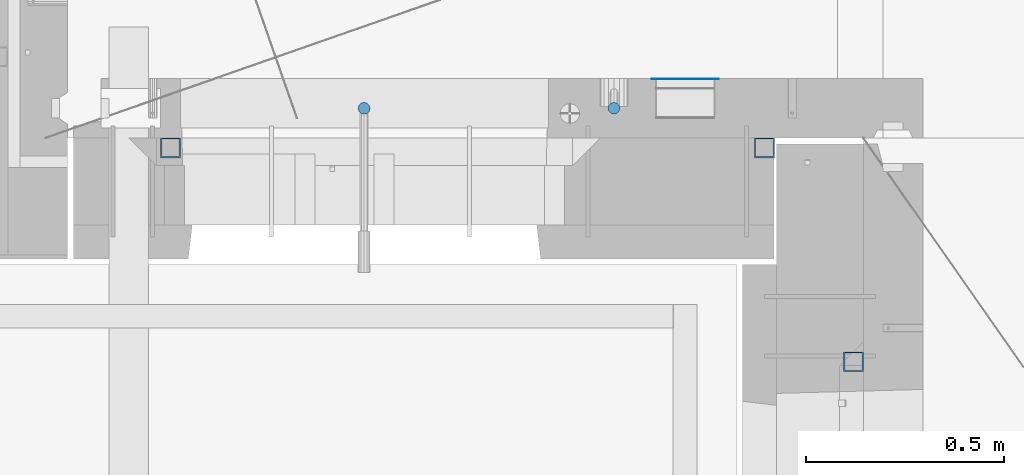
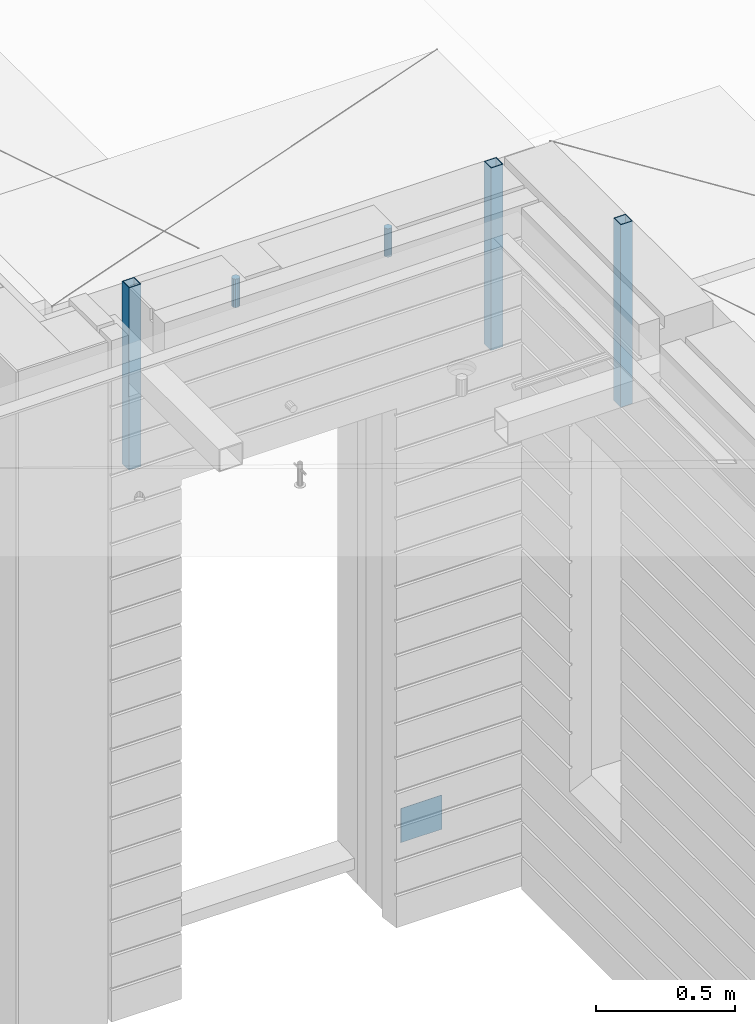
# One storey, part 12 of 350: 6 columns, 6 elements without a shape of their own.
"""IFC2X3 building model written with IfcOpenShell, lengths in millimetres."""

from ifc_helpers import new_model, si_unit, frame, origin_with_axes, place, context, subcontext, project, spatial, faceted_brep, material, type_object, element, aggregate, save


model = new_model("IFC2X3")

# Units and contexts
model_context = context("Model", 3, precision=1e-05, world=origin_with_axes())
body_context = subcontext(model_context, "Body", "Model", "MODEL_VIEW")
ifc_project = project(units=[si_unit("LENGTHUNIT", "METRE", prefix="MILLI"), si_unit("AREAUNIT", "SQUARE_METRE"), si_unit("VOLUMEUNIT", "CUBIC_METRE"), si_unit("MASSUNIT", "GRAM", prefix="KILO"), si_unit("TIMEUNIT", "SECOND"), si_unit("PLANEANGLEUNIT", "RADIAN"), si_unit("SOLIDANGLEUNIT", "STERADIAN"), si_unit("THERMODYNAMICTEMPERATUREUNIT", "DEGREE_CELSIUS"), si_unit("LUMINOUSINTENSITYUNIT", "LUMEN")], contexts=[model_context])

# Site, building, storey
site_placement = place(None, origin_with_axes())
site = spatial("IfcSite", under=ifc_project, at=site_placement, CompositionType="ELEMENT")
building_placement = place(site_placement, origin_with_axes())
building = spatial("IfcBuilding", under=site, at=building_placement, CompositionType="ELEMENT")
storey_placement = place(building_placement, origin_with_axes())
storey = spatial("IfcBuildingStorey", under=building, at=storey_placement, Name="2", CompositionType="ELEMENT", Elevation=0.0)

# Assemblies, columns
assembly_1_placement = place(storey_placement, origin_with_axes())
assembly_1 = element("IfcElementAssembly", 1, at=assembly_1_placement, inside=storey, AssemblyPlace="NOTDEFINED", PredefinedType="REINFORCEMENT_UNIT")
ifc_material_1 = material()
column_type_1 = type_object("IfcColumnType", Name="D30", PredefinedType="NOTDEFINED")
column_1_placement = place(assembly_1_placement, frame((9379.99827996565, 11025.0, 87407.5), z_axis=(0.0, -1.0, 0.0), x_axis=(0.0, 0.0, 1.0)))
column_1 = element("IfcColumn", 2, at=column_1_placement, type_object=column_type_1, material=ifc_material_1, ObjectType="D30", context=body_context, shape_type="Brep", body=[
    faceted_brep([(0.0, -15.0, 0.0), (0.0, -12.9903810567666, -7.5), (125.0, -12.9903810567666, -7.5), (125.0, -15.0, 0.0), (0.0, -7.5, -12.9903810567666), (125.0, -7.5, -12.9903810567666), (0.0, 0.0, -15.0), (125.0, 0.0, -15.0), (0.0, 7.5, -12.9903810567666), (125.0, 7.5, -12.9903810567666), (0.0, 12.9903810567666, -7.5), (125.0, 12.9903810567666, -7.5), (0.0, 15.0, 0.0), (125.0, 15.0, 0.0), (0.0, 12.9903810567666, 7.5), (125.0, 12.9903810567666, 7.5), (0.0, 7.5, 12.9903810567666), (125.0, 7.5, 12.9903810567666), (0.0, 0.0, 15.0), (125.0, 0.0, 15.0), (0.0, -7.5, 12.9903810567666), (125.0, -7.5, 12.9903810567666), (0.0, -12.9903810567666, 7.5), (125.0, -12.9903810567666, 7.5)], [[[0, 1, 2, 3]], [[1, 4, 5, 2]], [[4, 6, 7, 5]], [[6, 8, 9, 7]], [[8, 10, 11, 9]], [[10, 12, 13, 11]], [[12, 14, 15, 13]], [[14, 16, 17, 15]], [[16, 18, 19, 17]], [[18, 20, 21, 19]], [[20, 22, 23, 21]], [[22, 0, 3, 23]], [[5, 7, 9, 11, 13, 15, 17, 19, 21, 23, 3, 2]], [[22, 20, 18, 16, 14, 12, 10, 8, 6, 4, 1, 0]]]),
])
column_2_placement = place(assembly_1_placement, frame((8748.99633326467, 11025.0000000071, 87407.5), z_axis=(0.0, 1.0, 0.0), x_axis=(0.0, 0.0, 1.0)))
column_2 = element("IfcColumn", 3, at=column_2_placement, type_object=column_type_1, material=ifc_material_1, ObjectType="D30", context=body_context, shape_type="Brep", body=[
    faceted_brep([(0.0, -15.0, 0.0), (0.0, -12.9903810567666, -7.5), (125.0, -12.9903810567666, -7.5), (125.0, -15.0, 0.0), (0.0, -7.5, -12.9903810567666), (125.0, -7.5, -12.9903810567666), (0.0, 0.0, -15.0), (125.0, 0.0, -15.0), (0.0, 7.5, -12.9903810567666), (125.0, 7.5, -12.9903810567666), (0.0, 12.9903810567666, -7.5), (125.0, 12.9903810567666, -7.5), (0.0, 15.0, 0.0), (125.0, 15.0, 0.0), (0.0, 12.9903810567666, 7.5), (125.0, 12.9903810567666, 7.5), (0.0, 7.5, 12.9903810567666), (125.0, 7.5, 12.9903810567666), (0.0, 0.0, 15.0), (125.0, 0.0, 15.0), (0.0, -7.5, 12.9903810567666), (125.0, -7.5, 12.9903810567666), (0.0, -12.9903810567666, 7.5), (125.0, -12.9903810567666, 7.5)], [[[0, 1, 2, 3]], [[1, 4, 5, 2]], [[4, 6, 7, 5]], [[6, 8, 9, 7]], [[8, 10, 11, 9]], [[10, 12, 13, 11]], [[12, 14, 15, 13]], [[14, 16, 17, 15]], [[16, 18, 19, 17]], [[18, 20, 21, 19]], [[20, 22, 23, 21]], [[22, 0, 3, 23]], [[5, 7, 9, 11, 13, 15, 17, 19, 21, 23, 3, 2]], [[22, 20, 18, 16, 14, 12, 10, 8, 6, 4, 1, 0]]]),
])
assembly_2_placement = place(assembly_1_placement, origin_with_axes())
assembly_2 = element("IfcElementAssembly", 4, at=assembly_2_placement, Name="Steel Assembly", AssemblyPlace="NOTDEFINED", PredefinedType="NOTDEFINED")
ifc_material_2 = material(Name="Undefined")
column_type_2 = type_object("IfcColumnType", PredefinedType="NOTDEFINED")
column_3_placement = place(assembly_2_placement, frame((9560.0000000031, 11098.9999999984, 84754.9999999985), z_axis=(0.0, 1.0, 0.0), x_axis=(0.0, 0.0, 1.0)))
column_3 = element("IfcColumn", 5, at=column_3_placement, type_object=column_type_2, material=ifc_material_2, Name="SPK2", context=body_context, shape_type="Brep", body=[
    faceted_brep([(0.0, 85.0, -1.0), (0.0, 85.0, 1.0), (150.0, 85.0, 1.0), (150.0, 85.0, -1.0), (0.0, -85.0, 1.0), (150.0, -85.0, 1.0), (0.0, -85.0, -1.0), (150.0, -85.0, -1.0)], [[[0, 1, 2, 3]], [[1, 4, 5, 2]], [[4, 6, 7, 5]], [[6, 0, 3, 7]], [[5, 7, 3, 2]], [[6, 4, 1, 0]]]),
])
aggregate(assembly_2, [column_3])
assembly_3_placement = place(assembly_1_placement, origin_with_axes())
assembly_3 = element("IfcElementAssembly", 6, at=assembly_3_placement, Name="Steel Assembly", AssemblyPlace="NOTDEFINED", PredefinedType="RIGID_FRAME")
ifc_material_3 = material(Name="STEEL/S355J2")
column_type_3 = type_object("IfcColumnType", Name="50X50X3", PredefinedType="NOTDEFINED")
column_4_placement = place(assembly_3_placement, frame((8260.0, 10925.0, 86940.0), z_axis=(1.0, 0.0, 0.0), x_axis=(0.0, 0.0, 1.0)))
column_4 = element("IfcColumn", 7, at=column_4_placement, type_object=column_type_3, material=ifc_material_3, ObjectType="50X50X3", context=body_context, shape_type="Brep", body=[
    faceted_brep([(0.0, 22.0, -22.0), (0.0, -22.0, -22.0), (800.0, -22.0, -22.0), (800.0, 22.0, -22.0), (0.0, -22.0, 22.0), (800.0, -22.0, 22.0), (0.0, 22.0, 22.0), (800.0, 22.0, 22.0), (0.0, 25.0, -25.0), (0.0, 25.0, 25.0), (800.0, 25.0, 25.0), (800.0, 25.0, -25.0), (0.0, -25.0, 25.0), (800.0, -25.0, 25.0), (0.0, -25.0, -25.0), (800.0, -25.0, -25.0)], [[[0, 1, 2, 3]], [[1, 4, 5, 2]], [[4, 6, 7, 5]], [[6, 0, 3, 7]], [[8, 9, 10, 11]], [[9, 12, 13, 10]], [[12, 14, 15, 13]], [[14, 8, 11, 15]], [[13, 15, 11, 10], [5, 7, 3, 2]], [[14, 12, 9, 8], [6, 4, 1, 0]]]),
])
aggregate(assembly_3, [column_4])
assembly_4_placement = place(assembly_1_placement, origin_with_axes())
assembly_4 = element("IfcElementAssembly", 8, at=assembly_4_placement, Name="Steel Assembly", AssemblyPlace="NOTDEFINED", PredefinedType="RIGID_FRAME")
aggregate(assembly_1, [column_1, column_2, assembly_2, assembly_3, assembly_4])
column_5_placement = place(assembly_4_placement, frame((9760.0, 10925.0, 86940.0), z_axis=(1.0, 0.0, 0.0), x_axis=(0.0, 0.0, 1.0)))
column_5 = element("IfcColumn", 9, at=column_5_placement, type_object=column_type_3, material=ifc_material_3, ObjectType="50X50X3", context=body_context, shape_type="Brep", body=[
    faceted_brep([(0.0, 22.0, -22.0), (0.0, -22.0, -22.0), (800.0, -22.0, -22.0), (800.0, 22.0, -22.0), (0.0, -22.0, 22.0), (800.0, -22.0, 22.0), (0.0, 22.0, 22.0), (800.0, 22.0, 22.0), (0.0, 25.0, -25.0), (0.0, 25.0, 25.0), (800.0, 25.0, 25.0), (800.0, 25.0, -25.0), (0.0, -25.0, 25.0), (800.0, -25.0, 25.0), (0.0, -25.0, -25.0), (800.0, -25.0, -25.0)], [[[0, 1, 2, 3]], [[1, 4, 5, 2]], [[4, 6, 7, 5]], [[6, 0, 3, 7]], [[8, 9, 10, 11]], [[9, 12, 13, 10]], [[12, 14, 15, 13]], [[14, 8, 11, 15]], [[13, 15, 11, 10], [5, 7, 3, 2]], [[14, 12, 9, 8], [6, 4, 1, 0]]]),
])
aggregate(assembly_4, [column_5])

# Assemblies, column
assembly_5_placement = place(storey_placement, origin_with_axes())
assembly_5 = element("IfcElementAssembly", 10, at=assembly_5_placement, inside=storey, AssemblyPlace="NOTDEFINED", PredefinedType="REINFORCEMENT_UNIT")
assembly_6_placement = place(assembly_5_placement, origin_with_axes())
assembly_6 = element("IfcElementAssembly", 11, at=assembly_6_placement, Name="Steel Assembly", AssemblyPlace="NOTDEFINED", PredefinedType="RIGID_FRAME")
aggregate(assembly_5, [assembly_6])
column_6_placement = place(assembly_6_placement, frame((9985.0, 10385.0, 86940.0), z_axis=(0.0, 1.0, 0.0), x_axis=(0.0, 0.0, 1.0)))
column_6 = element("IfcColumn", 12, at=column_6_placement, type_object=column_type_3, material=ifc_material_3, ObjectType="50X50X3", context=body_context, shape_type="Brep", body=[
    faceted_brep([(0.0, 22.0, -22.0), (0.0, -22.0, -22.0), (800.0, -22.0, -22.0), (800.0, 22.0, -22.0), (0.0, -22.0, 22.0), (800.0, -22.0, 22.0), (0.0, 22.0, 22.0), (800.0, 22.0, 22.0), (0.0, 25.0, -25.0), (0.0, 25.0, 25.0), (800.0, 25.0, 25.0), (800.0, 25.0, -25.0), (0.0, -25.0, 25.0), (800.0, -25.0, 25.0), (0.0, -25.0, -25.0), (800.0, -25.0, -25.0)], [[[0, 1, 2, 3]], [[1, 4, 5, 2]], [[4, 6, 7, 5]], [[6, 0, 3, 7]], [[8, 9, 10, 11]], [[9, 12, 13, 10]], [[12, 14, 15, 13]], [[14, 8, 11, 15]], [[13, 15, 11, 10], [5, 7, 3, 2]], [[14, 12, 9, 8], [6, 4, 1, 0]]]),
])
aggregate(assembly_6, [column_6])

save(model, "model.ifc")
